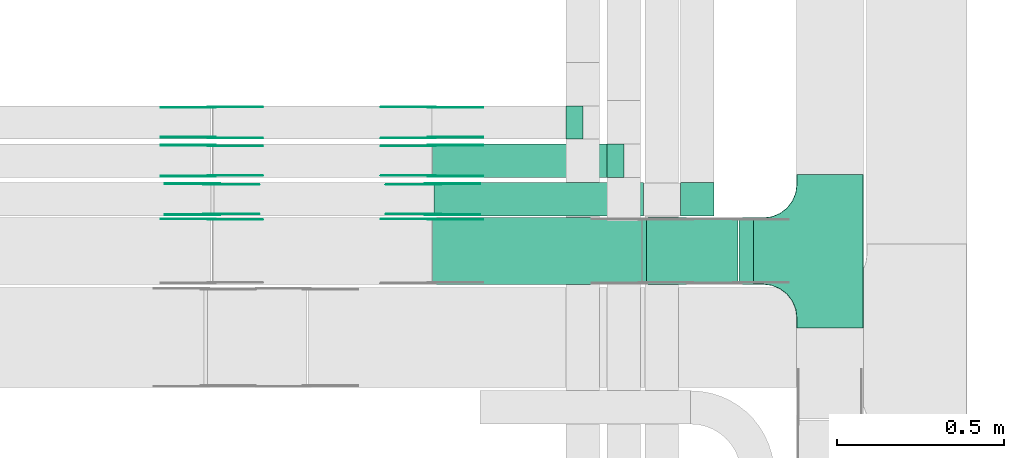
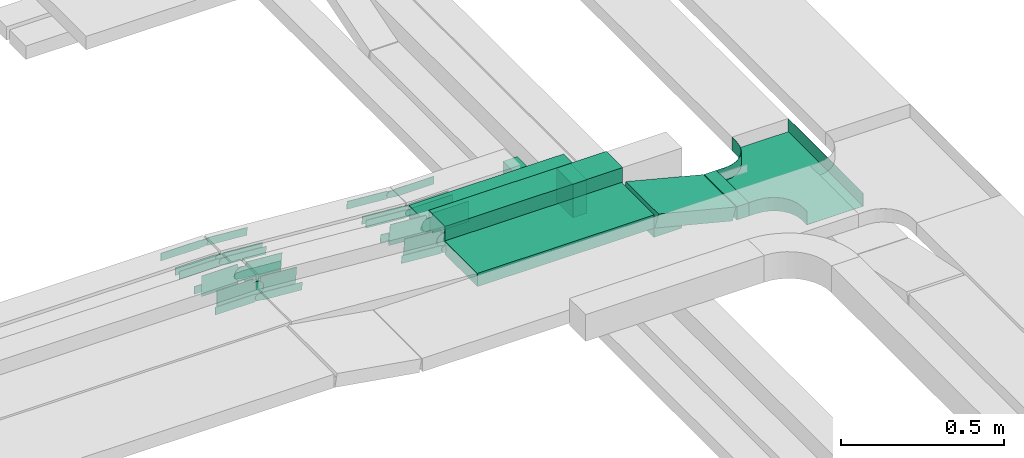
# One storey, part 5 of 19: 29 flow fittings, 8 flow segments.
"""IFC2X3 building model written with IfcOpenShell, lengths in millimetres."""

from ifc_helpers import new_model, entity, si_unit, converted_unit, derived_unit, direction, frame, frame_2d, origin, origin_2d_with_axis, place, context, subcontext, project, spatial, polyline, circle_curve, parameter, trimmed, segment, composite_curve, rectangle, outline, extrude, faceted_brep, source, transform, mapped, material, type_object, type_shapes, element, save


model = new_model("IFC2X3")

# Units and contexts
model_context = context("Model", 3, precision=0.01, world=origin(), true_north=direction((6.12303176911189e-17, 1.0)))
body_context = subcontext(model_context, "Body", "Model", "MODEL_VIEW")
ifc_project = project(units=[si_unit("LENGTHUNIT", "METRE", prefix="MILLI"), si_unit("AREAUNIT", "SQUARE_METRE"), si_unit("VOLUMEUNIT", "CUBIC_METRE"), converted_unit("PLANEANGLEUNIT", "DEGREE", entity("IfcRatioMeasure", 0.0174532925199433), si_unit("PLANEANGLEUNIT", "RADIAN"), dimensions=[0, 0, 0, 0, 0, 0, 0]), si_unit("MASSUNIT", "GRAM", prefix="KILO"), derived_unit("MASSDENSITYUNIT", [(si_unit("MASSUNIT", "GRAM", prefix="KILO"), 1), (si_unit("LENGTHUNIT", "METRE"), -3)]), derived_unit("MOMENTOFINERTIAUNIT", [(si_unit("LENGTHUNIT", "METRE"), 4)]), si_unit("TIMEUNIT", "SECOND"), si_unit("FREQUENCYUNIT", "HERTZ"), si_unit("THERMODYNAMICTEMPERATUREUNIT", "DEGREE_CELSIUS"), derived_unit("THERMALTRANSMITTANCEUNIT", [(si_unit("MASSUNIT", "GRAM", prefix="KILO"), 1), (si_unit("THERMODYNAMICTEMPERATUREUNIT", "KELVIN"), -1), (si_unit("TIMEUNIT", "SECOND"), -3)]), derived_unit("VOLUMETRICFLOWRATEUNIT", [(si_unit("LENGTHUNIT", "METRE"), 3), (si_unit("TIMEUNIT", "SECOND"), -1)]), derived_unit("MASSFLOWRATEUNIT", [(si_unit("MASSUNIT", "GRAM", prefix="KILO"), 1), (si_unit("TIMEUNIT", "SECOND"), -1)]), derived_unit("ROTATIONALFREQUENCYUNIT", [(si_unit("TIMEUNIT", "SECOND"), -1)]), si_unit("ELECTRICCURRENTUNIT", "AMPERE"), si_unit("ELECTRICVOLTAGEUNIT", "VOLT"), si_unit("POWERUNIT", "WATT"), si_unit("FORCEUNIT", "NEWTON", prefix="KILO"), si_unit("ILLUMINANCEUNIT", "LUX"), si_unit("LUMINOUSFLUXUNIT", "LUMEN"), si_unit("LUMINOUSINTENSITYUNIT", "CANDELA"), derived_unit("USERDEFINED", [(si_unit("MASSUNIT", "GRAM", prefix="KILO"), -1), (si_unit("LENGTHUNIT", "METRE"), -2), (si_unit("TIMEUNIT", "SECOND"), 3), (si_unit("LUMINOUSFLUXUNIT", "LUMEN"), 1)]), derived_unit("LINEARVELOCITYUNIT", [(si_unit("LENGTHUNIT", "METRE"), 1), (si_unit("TIMEUNIT", "SECOND"), -1)]), si_unit("PRESSUREUNIT", "PASCAL"), derived_unit("USERDEFINED", [(si_unit("LENGTHUNIT", "METRE"), -2), (si_unit("MASSUNIT", "GRAM", prefix="KILO"), 1), (si_unit("TIMEUNIT", "SECOND"), -2)]), derived_unit("LINEARFORCEUNIT", [(si_unit("MASSUNIT", "GRAM", prefix="KILO"), 1), (si_unit("LENGTHUNIT", "METRE"), 1), (si_unit("TIMEUNIT", "SECOND"), -2), (si_unit("LENGTHUNIT", "METRE"), -1)]), derived_unit("PLANARFORCEUNIT", [(si_unit("MASSUNIT", "GRAM", prefix="KILO"), 1), (si_unit("LENGTHUNIT", "METRE"), 1), (si_unit("TIMEUNIT", "SECOND"), -2), (si_unit("LENGTHUNIT", "METRE"), -2)])], contexts=[model_context])

# Site, building, storey
site_placement = place(None, origin())
site = spatial("IfcSite", under=ifc_project, at=site_placement, CompositionType="ELEMENT")
building_placement = place(site_placement, origin())
building = spatial("IfcBuilding", under=site, at=building_placement, CompositionType="ELEMENT")
storey_placement = place(building_placement, frame((0.0, 0.0, 12000.0)))
storey = spatial("IfcBuildingStorey", under=building, at=storey_placement, CompositionType="ELEMENT", Elevation=12000.0)

# Flow segments
cable_carrier_segment_type = type_object("IfcCableCarrierSegmentType", PredefinedType="CABLETRAYSEGMENT")
flow_segment_1_placement = place(storey_placement, frame((16932.33, 12764.16, 2799.71)))
element("IfcFlowSegment", 1, at=flow_segment_1_placement, inside=storey, type_object=cable_carrier_segment_type, context=body_context, shape_type="SweptSolid", body=[
    extrude(rectangle(XDim=627.939695827148, YDim=99.9999996045748, at=origin_2d_with_axis()), frame((314.02, 50.0, 0.14), z_axis=(-0.000454953936678616, 0.0, 0.999999896508452), x_axis=(-0.999999896508452, 0.0, -0.000454953936678616)), (0.0, 0.0, 1.0), 99.9999996045756),
])
flow_segment_2_placement = place(storey_placement, frame((16927.61, 12879.44, 2800.0)))
element("IfcFlowSegment", 2, at=flow_segment_2_placement, inside=storey, type_object=cable_carrier_segment_type, context=body_context, shape_type="SweptSolid", body=[
    extrude(rectangle(XDim=548.189497841086, YDim=99.9999999999989, at=origin_2d_with_axis()), frame((274.09, 50.0, 0.0)), (0.0, 0.0, 1.0), 49.9999999999995),
])
flow_segment_3_placement = place(storey_placement, frame((17845.8, 12558.8, 2727.85)))
element("IfcFlowSegment", 3, at=flow_segment_3_placement, inside=storey, type_object=cable_carrier_segment_type, context=body_context, shape_type="SweptSolid", body=[
    extrude(rectangle(XDim=42.7911006156176, YDim=200.000000000002, at=origin_2d_with_axis()), frame((21.4, 100.0, 0.0), z_axis=(0.0, 0.0, 1.0), x_axis=(-1.0, 0.0, 0.0)), (0.0, 0.0, 1.0), 49.9999999999995),
])
flow_segment_4_placement = place(storey_placement, frame((17556.1, 12558.8, 2729.77)))
element("IfcFlowSegment", 4, at=flow_segment_4_placement, inside=storey, type_object=cable_carrier_segment_type, context=body_context, shape_type="SweptSolid", body=[
    extrude(rectangle(XDim=50.0000000000006, YDim=199.999999999998, at=origin_2d_with_axis()), frame((6.17, 100.0, 94.09), z_axis=(0.969084530600964, 0.0, -0.246728945504798), x_axis=(0.246728945504798, 0.0, 0.969084530600964)), (0.0, 0.0, 1.0), 283.157457802594),
])
for number, where in (
    (5, (17327.76, 12994.16, 2680.0)),
    (6, (17450.8, 12879.44, 2680.0)),
):
    element("IfcFlowSegment", number, at=place(storey_placement, frame(where)), inside=storey, type_object=cable_carrier_segment_type, context=body_context, shape_type="SweptSolid", body=[
        extrude(rectangle(XDim=99.9999999999989, YDim=50.0000000000016, at=origin_2d_with_axis()), frame((25.0, 50.0, 0.0), z_axis=(0.0, 0.0, 1.0), x_axis=(0.0, 1.0, 0.0)), (0.0, 0.0, 1.0), 125.0),
    ])
flow_segment_5_placement = place(storey_placement, frame((17670.3, 12764.16, 2600.0)))
element("IfcFlowSegment", 7, at=flow_segment_5_placement, inside=storey, type_object=cable_carrier_segment_type, context=body_context, shape_type="SweptSolid", body=[
    extrude(rectangle(XDim=99.9999999999989, YDim=99.9999999999989, at=origin_2d_with_axis()), frame((50.0, 50.0, 0.0), z_axis=(0.0, 0.0, 1.0), x_axis=(-1.0, 0.0, 0.0)), (0.0, 0.0, 1.0), 90.000000000038),
])
flow_segment_6_placement = place(storey_placement, frame((16927.61, 12558.8, 2800.0)))
element("IfcFlowSegment", 8, at=flow_segment_6_placement, inside=storey, type_object=cable_carrier_segment_type, context=body_context, shape_type="SweptSolid", body=[
    extrude(rectangle(XDim=625.530791542038, YDim=199.999999999998, at=origin_2d_with_axis()), frame((312.77, 100.0, 0.0)), (0.0, 0.0, 1.0), 50.0000000000016),
])

# Flow fittings
ifc_material_1 = material()
cable_carrier_fitting_type_1 = type_object("IfcCableCarrierFittingType", PredefinedType="NOTDEFINED", material=ifc_material_1)
shared_shape_1 = source(origin(), body_context, "Body", "Brep", [
    faceted_brep([(-103.41, -174.12, 25.0), (-100.0, -200.0, 25.0), (-100.0, -230.0, 25.0), (-99.2, -230.0, 25.0), (-99.2, -200.0, 25.0), (-102.63, -173.91, 25.0), (-112.7, -149.6, 25.0), (-128.72, -128.72, 25.0), (-149.6, -112.7, 25.0), (-173.91, -102.63, 25.0), (-200.0, -99.2, 25.0), (-230.0, -99.2, 25.0), (-230.0, -100.0, 25.0), (-200.0, -100.0, 25.0), (-174.12, -103.41, 25.0), (-150.0, -113.4, 25.0), (-129.29, -129.29, 25.0), (-113.4, -150.0, 25.0), (230.0, -100.0, 25.0), (230.0, -99.2, 25.0), (200.0, -99.2, 25.0), (173.91, -102.63, 25.0), (149.6, -112.7, 25.0), (128.72, -128.72, 25.0), (112.7, -149.6, 25.0), (102.63, -173.91, 25.0), (99.2, -200.0, 25.0), (99.2, -230.0, 25.0), (100.0, -230.0, 25.0), (100.0, -200.0, 25.0), (103.41, -174.12, 25.0), (113.4, -150.0, 25.0), (129.29, -129.29, 25.0), (150.0, -113.4, 25.0), (174.12, -103.41, 25.0), (200.0, -100.0, 25.0), (230.0, 99.2, 25.0), (230.0, 100.0, 25.0), (-230.0, 100.0, 25.0), (-230.0, 99.2, 25.0), (-230.0, -100.0, -25.0), (-230.0, 100.0, -25.0), (230.0, 100.0, -25.0), (230.0, -100.0, -25.0), (200.0, -100.0, -25.0), (174.12, -103.41, -25.0), (150.0, -113.4, -25.0), (129.29, -129.29, -25.0), (113.4, -150.0, -25.0), (103.41, -174.12, -25.0), (100.0, -200.0, -25.0), (100.0, -230.0, -25.0), (-100.0, -230.0, -25.0), (-100.0, -200.0, -25.0), (-103.41, -174.12, -25.0), (-113.4, -150.0, -25.0), (-129.29, -129.29, -25.0), (-150.0, -113.4, -25.0), (-174.12, -103.41, -25.0), (-200.0, -100.0, -25.0), (-100.0, -200.0, -24.2), (99.2, -230.0, -24.2), (-99.2, -230.0, -24.2), (-99.2, -200.0, -24.2), (-200.0, -99.2, -24.2), (-230.0, -99.2, -24.2), (230.0, -99.2, -24.2), (200.0, -99.2, -24.2), (-230.0, 99.2, -24.2), (-200.0, -100.0, -24.2), (200.0, -100.0, -24.2), (230.0, 99.2, -24.2), (99.2, -200.0, -24.2), (100.0, -200.0, -24.2), (-173.91, -102.63, -24.2), (-149.6, -112.7, -24.2), (-128.72, -128.72, -24.2), (-112.7, -149.6, -24.2), (-102.63, -173.91, -24.2), (102.63, -173.91, -24.2), (112.7, -149.6, -24.2), (128.72, -128.72, -24.2), (149.6, -112.7, -24.2), (173.91, -102.63, -24.2)], [[[0, 1, 2, 3, 4, 5, 6, 7, 8, 9, 10, 11, 12, 13, 14, 15, 16, 17]], [[18, 19, 20, 21, 22, 23, 24, 25, 26, 27, 28, 29, 30, 31, 32, 33, 34, 35]], [[36, 37, 38, 39]], [[40, 41, 42, 43, 44, 45, 46, 47, 48, 49, 50, 51, 52, 53, 54, 55, 56, 57, 58, 59]], [[2, 1, 60, 53, 52]], [[3, 2, 52, 51, 28, 27, 61, 62]], [[4, 3, 62, 63]], [[11, 10, 64, 65]], [[20, 19, 66, 67]], [[39, 38, 41, 40, 12, 11, 65, 68]], [[13, 12, 40, 59, 69]], [[18, 35, 70, 44, 43]], [[19, 18, 43, 42, 37, 36, 71, 66]], [[27, 26, 72, 61]], [[29, 28, 51, 50, 73]], [[38, 37, 42, 41]], [[36, 39, 68, 71]], [[68, 65, 64, 74, 75, 76, 77, 78, 63, 62, 61, 72, 79, 80, 81, 82, 83, 67, 66, 71]], [[14, 13, 69, 59, 58]], [[58, 57, 15, 14]], [[15, 57, 56, 16]], [[0, 17, 55, 54]], [[0, 54, 53, 60, 1]], [[55, 17, 16, 56]], [[5, 4, 63, 78]], [[6, 5, 78, 77]], [[7, 6, 77, 76]], [[8, 7, 76, 75]], [[9, 8, 75, 74]], [[10, 9, 74, 64]], [[21, 20, 67, 83]], [[22, 21, 83, 82]], [[23, 22, 82, 81]], [[81, 80, 24, 23]], [[24, 80, 79, 25]], [[79, 72, 26, 25]], [[30, 29, 73, 50, 49]], [[31, 30, 49, 48]], [[31, 48, 47, 32]], [[33, 32, 47, 46]], [[45, 34, 33, 46]], [[34, 45, 44, 70, 35]]]),
])
type_shapes(cable_carrier_fitting_type_1, [shared_shape_1])
flow_fitting_1_placement = place(storey_placement, frame((18118.59, 12658.8, 2752.85), z_axis=(0.0, 0.0, 1.0), x_axis=(0.0, -1.0, 0.0)))
element("IfcFlowFitting", 9, at=flow_fitting_1_placement, inside=storey, type_object=cable_carrier_fitting_type_1, material=ifc_material_1, Name="470_DKC_S5_T", context=body_context, shape_type="MappedRepresentation", body=[
    mapped(shared_shape_1, transform((0.0, 0.0, 0.0), scale=1.0)),
])
ifc_material_2 = material(Name="G")
cable_carrier_fitting_type_2 = type_object("IfcCableCarrierFittingType", PredefinedType="NOTDEFINED", material=ifc_material_2)
shared_shape_2 = source(origin(), body_context, "Body", "SweptSolid", [
    extrude(outline(composite_curve([segment(trimmed(circle_curve(frame_2d((-44.59, 0.0), x_axis=(1.0, 0.0)), 12.5), [parameter(90.0000000000007)], [parameter(270.0)], True, "PARAMETER"), True, "CONTINUOUS"), segment(polyline([(-44.59, -12.5), (-33.09, -12.5)]), True, "CONTINUOUS"), segment(polyline([(-33.09, -12.5), (-31.23, -14.5)]), True, "CONTINUOUS"), segment(polyline([(-31.23, -14.5), (108.91, -14.5)]), True, "CONTINUOUS"), segment(polyline([(108.91, -14.5), (108.91, 14.5)]), True, "CONTINUOUS"), segment(polyline([(108.91, 14.5), (-31.23, 14.5)]), True, "CONTINUOUS"), segment(polyline([(-31.23, 14.5), (-33.09, 12.5)]), True, "CONTINUOUS"), segment(polyline([(-33.09, 12.5), (-44.59, 12.5)]), True, "CONTINUOUS")], self_intersect=False)), frame((44.59, 0.0, 0.0), z_axis=(0.0, 0.0, -1.0), x_axis=(1.0, 0.0, 0.0)), (0.0, 0.0, -1.0), 2.0),
])
type_shapes(cable_carrier_fitting_type_2, [shared_shape_2])
flow_fitting_2_placement = place(storey_placement, frame((16266.34, 13089.62, 2875.0), z_axis=(0.0, 1.0, 0.0), x_axis=(0.997135526115969, 0.0, -0.0756355905472349)))
element("IfcFlowFitting", 10, at=flow_fitting_2_placement, inside=storey, type_object=cable_carrier_fitting_type_2, material=ifc_material_2, context=body_context, shape_type="MappedRepresentation", body=[
    mapped(shared_shape_2, transform((0.0, 0.0, 0.0), scale=1.0)),
])
cable_carrier_fitting_type_3 = type_object("IfcCableCarrierFittingType", PredefinedType="NOTDEFINED", material=ifc_material_2)
type_shapes(cable_carrier_fitting_type_3, [shared_shape_2])
flow_fitting_3_placement = place(storey_placement, frame((16266.34, 13000.7, 2875.0), z_axis=(0.0, -1.0, 0.0), x_axis=(-1.0, 0.0, 0.0)))
element("IfcFlowFitting", 11, at=flow_fitting_3_placement, inside=storey, type_object=cable_carrier_fitting_type_3, material=ifc_material_2, context=body_context, shape_type="MappedRepresentation", body=[
    mapped(shared_shape_2, transform((0.0, 0.0, 0.0), scale=1.0)),
])
flow_fitting_4_placement = place(storey_placement, frame((16925.52, 13089.62, 2825.0), z_axis=(0.0, 1.0, 0.0), x_axis=(-0.997135526115969, 0.0, 0.0756355905472349)))
element("IfcFlowFitting", 12, at=flow_fitting_4_placement, inside=storey, type_object=cable_carrier_fitting_type_2, material=ifc_material_2, context=body_context, shape_type="MappedRepresentation", body=[
    mapped(shared_shape_2, transform((0.0, 0.0, 0.0), scale=1.0)),
])
flow_fitting_5_placement = place(storey_placement, frame((16925.52, 13000.7, 2825.0), z_axis=(0.0, -1.0, 0.0), x_axis=(1.0, 0.0, 0.0)))
element("IfcFlowFitting", 13, at=flow_fitting_5_placement, inside=storey, type_object=cable_carrier_fitting_type_3, material=ifc_material_2, context=body_context, shape_type="MappedRepresentation", body=[
    mapped(shared_shape_2, transform((0.0, 0.0, 0.0), scale=1.0)),
])
flow_fitting_6_placement = place(storey_placement, frame((16925.52, 12883.98, 2825.0), z_axis=(0.0, -1.0, 0.0), x_axis=(1.0, 0.0, 0.0)))
element("IfcFlowFitting", 14, at=flow_fitting_6_placement, inside=storey, type_object=cable_carrier_fitting_type_2, material=ifc_material_2, context=body_context, shape_type="MappedRepresentation", body=[
    mapped(shared_shape_2, transform((0.0, 0.0, 0.0), scale=1.0)),
])
flow_fitting_7_placement = place(storey_placement, frame((16925.52, 12972.9, 2825.0), z_axis=(0.0, 1.0, 0.0), x_axis=(-0.99713552611597, 0.0, 0.0756355905472251)))
element("IfcFlowFitting", 15, at=flow_fitting_7_placement, inside=storey, type_object=cable_carrier_fitting_type_3, material=ifc_material_2, context=body_context, shape_type="MappedRepresentation", body=[
    mapped(shared_shape_2, transform((0.0, 0.0, 0.0), scale=1.0)),
])
flow_fitting_8_placement = place(storey_placement, frame((16266.34, 12883.98, 2875.0), z_axis=(0.0, -1.0, 0.0), x_axis=(-1.0, 0.0, 0.0)))
element("IfcFlowFitting", 16, at=flow_fitting_8_placement, inside=storey, type_object=cable_carrier_fitting_type_2, material=ifc_material_2, context=body_context, shape_type="MappedRepresentation", body=[
    mapped(shared_shape_2, transform((0.0, 0.0, 0.0), scale=1.0)),
])
flow_fitting_9_placement = place(storey_placement, frame((16266.34, 12972.9, 2875.0), z_axis=(0.0, 1.0, 0.0), x_axis=(0.99713552611597, 0.0, -0.0756355905472248)))
element("IfcFlowFitting", 17, at=flow_fitting_9_placement, inside=storey, type_object=cable_carrier_fitting_type_3, material=ifc_material_2, context=body_context, shape_type="MappedRepresentation", body=[
    mapped(shared_shape_2, transform((0.0, 0.0, 0.0), scale=1.0)),
])
flow_fitting_10_placement = place(storey_placement, frame((16925.52, 12754.26, 2825.0), z_axis=(0.0, 1.0, 0.0), x_axis=(-0.997135526115969, 0.0, 0.0756355905472349)))
element("IfcFlowFitting", 18, at=flow_fitting_10_placement, inside=storey, type_object=cable_carrier_fitting_type_2, material=ifc_material_2, context=body_context, shape_type="MappedRepresentation", body=[
    mapped(shared_shape_2, transform((0.0, 0.0, 0.0), scale=1.0)),
])
flow_fitting_11_placement = place(storey_placement, frame((16266.34, 12752.26, 2875.0), z_axis=(0.0, 1.0, 0.0), x_axis=(0.99713552611597, 0.0, -0.0756355905472288)))
element("IfcFlowFitting", 19, at=flow_fitting_11_placement, inside=storey, type_object=cable_carrier_fitting_type_3, material=ifc_material_2, context=body_context, shape_type="MappedRepresentation", body=[
    mapped(shared_shape_2, transform((0.0, 0.0, 0.0), scale=1.0)),
])
cable_carrier_fitting_type_4 = type_object("IfcCableCarrierFittingType", PredefinedType="NOTDEFINED", material=ifc_material_2)
shared_shape_3 = source(origin(), body_context, "Body", "SweptSolid", [
    extrude(outline(composite_curve([segment(trimmed(circle_curve(frame_2d((-44.59, 0.0), x_axis=(1.0, 0.0)), 12.5), [parameter(90.0000000000007)], [parameter(270.0)], True, "PARAMETER"), True, "CONTINUOUS"), segment(polyline([(-44.59, -12.5), (-33.09, -12.5)]), True, "CONTINUOUS"), segment(polyline([(-33.09, -12.5), (-31.23, -14.5)]), True, "CONTINUOUS"), segment(polyline([(-31.23, -14.5), (108.91, -14.5)]), True, "CONTINUOUS"), segment(polyline([(108.91, -14.5), (108.91, 14.5)]), True, "CONTINUOUS"), segment(polyline([(108.91, 14.5), (-31.23, 14.5)]), True, "CONTINUOUS"), segment(polyline([(-31.23, 14.5), (-33.09, 12.5)]), True, "CONTINUOUS"), segment(polyline([(-33.09, 12.5), (-44.59, 12.5)]), True, "CONTINUOUS")], self_intersect=False)), frame((44.59, 0.0, 0.0)), (0.0, 0.0, 1.0), 2.0),
])
type_shapes(cable_carrier_fitting_type_4, [shared_shape_3])
flow_fitting_12_placement = place(storey_placement, frame((16266.34, 12998.7, 2875.0), z_axis=(0.0, -1.0, 0.0), x_axis=(0.997135526115969, 0.0, -0.0756355905472349)))
element("IfcFlowFitting", 20, at=flow_fitting_12_placement, inside=storey, type_object=cable_carrier_fitting_type_4, material=ifc_material_2, context=body_context, shape_type="MappedRepresentation", body=[
    mapped(shared_shape_3, transform((0.0, 0.0, 0.0), scale=1.0)),
])
cable_carrier_fitting_type_5 = type_object("IfcCableCarrierFittingType", PredefinedType="NOTDEFINED", material=ifc_material_2)
type_shapes(cable_carrier_fitting_type_5, [shared_shape_3])
flow_fitting_13_placement = place(storey_placement, frame((16266.34, 13087.62, 2875.0), z_axis=(0.0, 1.0, 0.0), x_axis=(-1.0, 0.0, 0.0)))
element("IfcFlowFitting", 21, at=flow_fitting_13_placement, inside=storey, type_object=cable_carrier_fitting_type_5, material=ifc_material_2, context=body_context, shape_type="MappedRepresentation", body=[
    mapped(shared_shape_3, transform((0.0, 0.0, 0.0), scale=1.0)),
])
flow_fitting_14_placement = place(storey_placement, frame((16925.52, 12998.7, 2825.0), z_axis=(0.0, -1.0, 0.0), x_axis=(-0.997135526115969, 0.0, 0.0756355905472349)))
element("IfcFlowFitting", 22, at=flow_fitting_14_placement, inside=storey, type_object=cable_carrier_fitting_type_4, material=ifc_material_2, context=body_context, shape_type="MappedRepresentation", body=[
    mapped(shared_shape_3, transform((0.0, 0.0, 0.0), scale=1.0)),
])
flow_fitting_15_placement = place(storey_placement, frame((16925.52, 13087.62, 2825.0), z_axis=(0.0, 1.0, 0.0), x_axis=(1.0, 0.0, 0.0)))
element("IfcFlowFitting", 23, at=flow_fitting_15_placement, inside=storey, type_object=cable_carrier_fitting_type_5, material=ifc_material_2, context=body_context, shape_type="MappedRepresentation", body=[
    mapped(shared_shape_3, transform((0.0, 0.0, 0.0), scale=1.0)),
])
flow_fitting_16_placement = place(storey_placement, frame((16925.52, 12974.9, 2825.0), z_axis=(0.0, 1.0, 0.0), x_axis=(1.0, 0.0, 0.0)))
element("IfcFlowFitting", 24, at=flow_fitting_16_placement, inside=storey, type_object=cable_carrier_fitting_type_4, material=ifc_material_2, context=body_context, shape_type="MappedRepresentation", body=[
    mapped(shared_shape_3, transform((0.0, 0.0, 0.0), scale=1.0)),
])
flow_fitting_17_placement = place(storey_placement, frame((16925.52, 12885.98, 2825.0), z_axis=(0.0, -1.0, 0.0), x_axis=(-0.99713552611597, 0.0, 0.0756355905472251)))
element("IfcFlowFitting", 25, at=flow_fitting_17_placement, inside=storey, type_object=cable_carrier_fitting_type_5, material=ifc_material_2, context=body_context, shape_type="MappedRepresentation", body=[
    mapped(shared_shape_3, transform((0.0, 0.0, 0.0), scale=1.0)),
])
flow_fitting_18_placement = place(storey_placement, frame((16266.34, 12974.9, 2875.0), z_axis=(0.0, 1.0, 0.0), x_axis=(-1.0, 0.0, 0.0)))
element("IfcFlowFitting", 26, at=flow_fitting_18_placement, inside=storey, type_object=cable_carrier_fitting_type_4, material=ifc_material_2, context=body_context, shape_type="MappedRepresentation", body=[
    mapped(shared_shape_3, transform((0.0, 0.0, 0.0), scale=1.0)),
])
for number, where, z_axis, x_axis in (
    (27, (16266.34, 12885.98, 2875.0), (0.0, -1.0, 0.0), (0.99713552611597, 0.0, -0.0756355905472248)),
    (28, (16925.52, 12752.26, 2825.0), (0.0, 1.0, 0.0), (1.0, 0.0, 0.0)),
):
    element("IfcFlowFitting", number, at=place(storey_placement, frame(where, z_axis=z_axis, x_axis=x_axis)), inside=storey, type_object=cable_carrier_fitting_type_5, material=ifc_material_2, context=body_context, shape_type="MappedRepresentation", body=[
        mapped(shared_shape_3, transform((0.0, 0.0, 0.0), scale=1.0)),
    ])
flow_fitting_19_placement = place(storey_placement, frame((16266.34, 12754.26, 2875.0), z_axis=(0.0, 1.0, 0.0), x_axis=(-1.0, 0.0, 0.0)))
element("IfcFlowFitting", 29, at=flow_fitting_19_placement, inside=storey, type_object=cable_carrier_fitting_type_4, material=ifc_material_2, context=body_context, shape_type="MappedRepresentation", body=[
    mapped(shared_shape_3, transform((0.0, 0.0, 0.0), scale=1.0)),
])
cable_carrier_fitting_type_6 = type_object("IfcCableCarrierFittingType", PredefinedType="NOTDEFINED", material=ifc_material_2)
shared_shape_4 = source(origin(), body_context, "Body", "SweptSolid", [
    extrude(outline(composite_curve([segment(trimmed(circle_curve(frame_2d((-41.47, 0.0), x_axis=(1.0, 0.0)), 25.0), [parameter(90.0000000000007)], [parameter(270.0)], True, "PARAMETER"), True, "CONTINUOUS"), segment(polyline([(-41.47, -25.0), (-29.97, -25.0)]), True, "CONTINUOUS"), segment(polyline([(-29.97, -25.0), (-28.1, -38.5)]), True, "CONTINUOUS"), segment(polyline([(-28.1, -38.5), (99.53, -38.5)]), True, "CONTINUOUS"), segment(polyline([(99.53, -38.5), (99.53, 38.5)]), True, "CONTINUOUS"), segment(polyline([(99.53, 38.5), (-28.1, 38.5)]), True, "CONTINUOUS"), segment(polyline([(-28.1, 38.5), (-29.97, 25.0)]), True, "CONTINUOUS"), segment(polyline([(-29.97, 25.0), (-41.47, 25.0)]), True, "CONTINUOUS")], self_intersect=False)), frame((41.47, 0.0, 0.0), z_axis=(0.0, 0.0, -1.0), x_axis=(1.0, 0.0, 0.0)), (0.0, 0.0, -1.0), 2.0),
])
type_shapes(cable_carrier_fitting_type_6, [shared_shape_4])
flow_fitting_20_placement = place(storey_placement, frame((16929.3, 12768.7, 2849.71), z_axis=(0.0, -1.0, 0.0), x_axis=(0.999999896508455, 0.0, 0.000454953931720556)))
element("IfcFlowFitting", 30, at=flow_fitting_20_placement, inside=storey, type_object=cable_carrier_fitting_type_6, material=ifc_material_2, context=body_context, shape_type="MappedRepresentation", body=[
    mapped(shared_shape_4, transform((0.0, 0.0, 0.0), scale=1.0)),
])
cable_carrier_fitting_type_7 = type_object("IfcCableCarrierFittingType", PredefinedType="NOTDEFINED", material=ifc_material_2)
type_shapes(cable_carrier_fitting_type_7, [shared_shape_4])
flow_fitting_21_placement = place(storey_placement, frame((16929.3, 12857.62, 2849.71), z_axis=(0.0, 1.0, 0.0), x_axis=(-0.99713552611597, 0.0, 0.0756355905472225)))
element("IfcFlowFitting", 31, at=flow_fitting_21_placement, inside=storey, type_object=cable_carrier_fitting_type_7, material=ifc_material_2, context=body_context, shape_type="MappedRepresentation", body=[
    mapped(shared_shape_4, transform((0.0, 0.0, 0.0), scale=1.0)),
])
flow_fitting_22_placement = place(storey_placement, frame((16266.34, 12768.7, 2900.0), z_axis=(0.0, -1.0, 0.0), x_axis=(-1.0, 0.0, 0.0)))
element("IfcFlowFitting", 32, at=flow_fitting_22_placement, inside=storey, type_object=cable_carrier_fitting_type_6, material=ifc_material_2, context=body_context, shape_type="MappedRepresentation", body=[
    mapped(shared_shape_4, transform((0.0, 0.0, 0.0), scale=1.0)),
])
flow_fitting_23_placement = place(storey_placement, frame((16266.34, 12857.62, 2900.0), z_axis=(0.0, 1.0, 0.0), x_axis=(0.99713552611597, 0.0, -0.0756355905472226)))
element("IfcFlowFitting", 33, at=flow_fitting_23_placement, inside=storey, type_object=cable_carrier_fitting_type_7, material=ifc_material_2, context=body_context, shape_type="MappedRepresentation", body=[
    mapped(shared_shape_4, transform((0.0, 0.0, 0.0), scale=1.0)),
])
cable_carrier_fitting_type_8 = type_object("IfcCableCarrierFittingType", PredefinedType="NOTDEFINED", material=ifc_material_2)
shared_shape_5 = source(origin(), body_context, "Body", "SweptSolid", [
    extrude(outline(composite_curve([segment(trimmed(circle_curve(frame_2d((-41.47, 0.0), x_axis=(1.0, 0.0)), 25.0), [parameter(90.0000000000007)], [parameter(270.0)], True, "PARAMETER"), True, "CONTINUOUS"), segment(polyline([(-41.47, -25.0), (-29.97, -25.0)]), True, "CONTINUOUS"), segment(polyline([(-29.97, -25.0), (-28.1, -38.5)]), True, "CONTINUOUS"), segment(polyline([(-28.1, -38.5), (99.53, -38.5)]), True, "CONTINUOUS"), segment(polyline([(99.53, -38.5), (99.53, 38.5)]), True, "CONTINUOUS"), segment(polyline([(99.53, 38.5), (-28.1, 38.5)]), True, "CONTINUOUS"), segment(polyline([(-28.1, 38.5), (-29.97, 25.0)]), True, "CONTINUOUS"), segment(polyline([(-29.97, 25.0), (-41.47, 25.0)]), True, "CONTINUOUS")], self_intersect=False)), frame((41.47, 0.0, 0.0)), (0.0, 0.0, 1.0), 2.0),
])
type_shapes(cable_carrier_fitting_type_8, [shared_shape_5])
flow_fitting_24_placement = place(storey_placement, frame((16929.3, 12859.62, 2849.71), z_axis=(0.0, 1.0, 0.0), x_axis=(0.999999896508455, 0.0, 0.000454953931720556)))
element("IfcFlowFitting", 34, at=flow_fitting_24_placement, inside=storey, type_object=cable_carrier_fitting_type_8, material=ifc_material_2, context=body_context, shape_type="MappedRepresentation", body=[
    mapped(shared_shape_5, transform((0.0, 0.0, 0.0), scale=1.0)),
])
cable_carrier_fitting_type_9 = type_object("IfcCableCarrierFittingType", PredefinedType="NOTDEFINED", material=ifc_material_2)
type_shapes(cable_carrier_fitting_type_9, [shared_shape_5])
flow_fitting_25_placement = place(storey_placement, frame((16929.3, 12770.7, 2849.71), z_axis=(0.0, -1.0, 0.0), x_axis=(-0.99713552611597, 0.0, 0.0756355905472225)))
element("IfcFlowFitting", 35, at=flow_fitting_25_placement, inside=storey, type_object=cable_carrier_fitting_type_9, material=ifc_material_2, context=body_context, shape_type="MappedRepresentation", body=[
    mapped(shared_shape_5, transform((0.0, 0.0, 0.0), scale=1.0)),
])
flow_fitting_26_placement = place(storey_placement, frame((16266.34, 12859.62, 2900.0), z_axis=(0.0, 1.0, 0.0), x_axis=(-1.0, 0.0, 0.0)))
element("IfcFlowFitting", 36, at=flow_fitting_26_placement, inside=storey, type_object=cable_carrier_fitting_type_8, material=ifc_material_2, context=body_context, shape_type="MappedRepresentation", body=[
    mapped(shared_shape_5, transform((0.0, 0.0, 0.0), scale=1.0)),
])
flow_fitting_27_placement = place(storey_placement, frame((16266.34, 12770.7, 2900.0), z_axis=(0.0, -1.0, 0.0), x_axis=(0.99713552611597, 0.0, -0.0756355905472226)))
element("IfcFlowFitting", 37, at=flow_fitting_27_placement, inside=storey, type_object=cable_carrier_fitting_type_9, material=ifc_material_2, context=body_context, shape_type="MappedRepresentation", body=[
    mapped(shared_shape_5, transform((0.0, 0.0, 0.0), scale=1.0)),
])

save(model, "model.ifc")
